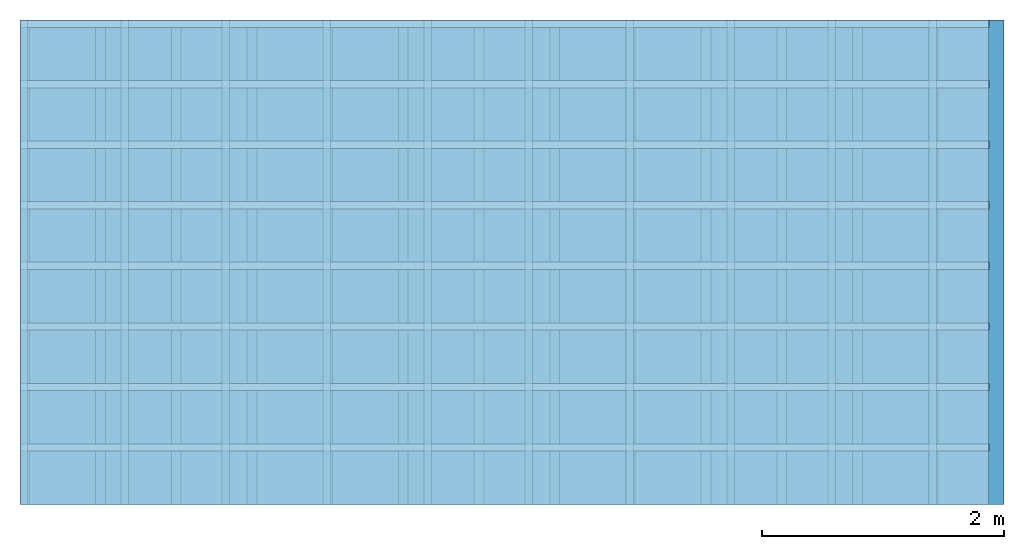
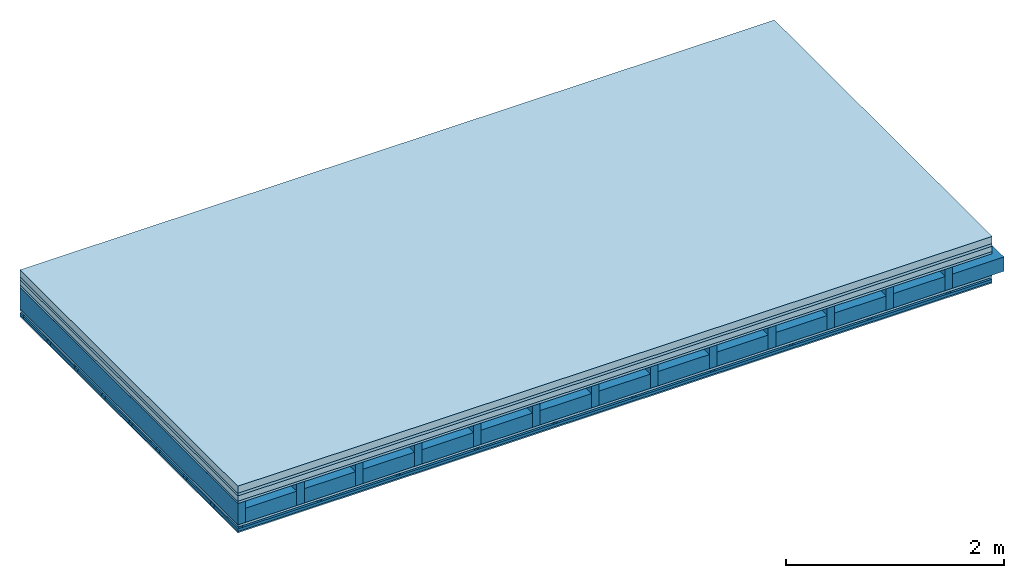
# One storey: 6 plates, 5 members, 1 element without a shape of its own.
"""IFC4 building model written with IfcOpenShell, lengths in metres."""

from ifc_helpers import new_model, si_unit, derived_unit, direction, frame, frame_2d, origin, origin_with_axes, place, context, project, spatial, polyline, rectangle, outline, extrude, material, layer, layer_set, type_object, element, aggregate, save


model = new_model("IFC4")

# Units and contexts
plan_context = context("Plan", 3, precision=1e-05, world=origin(), true_north=direction((0.0, 1.0)))
model_context = context("Model", 3, precision=1e-05, world=origin(), true_north=direction((0.0, 1.0)))
ifc_project = project(units=[si_unit("LENGTHUNIT", "METRE"), derived_unit("SOUNDPRESSUREUNIT", [(si_unit("PRESSUREUNIT", "PASCAL", prefix="MICRO"), 0)]), si_unit("ENERGYUNIT", "JOULE", prefix="MEGA"), si_unit("MASSUNIT", "GRAM", prefix="KILO"), derived_unit("THERMALTRANSMITTANCEUNIT", [(si_unit("POWERUNIT", "WATT"), 1), (si_unit("AREAUNIT", "SQUARE_METRE"), -1), (si_unit("THERMODYNAMICTEMPERATUREUNIT", "KELVIN"), -1)]), derived_unit("AREADENSITYUNIT", [(si_unit("MASSUNIT", "GRAM", prefix="KILO"), 1), (si_unit("AREAUNIT", "SQUARE_METRE"), -1)]), derived_unit("USERDEFINED", [(si_unit("ENERGYUNIT", "JOULE", prefix="MEGA"), 1), (si_unit("AREAUNIT", "SQUARE_METRE"), -1)])], contexts=[plan_context, model_context])

# Site, building, storey
site = spatial("IfcSite", under=ifc_project)
building_placement = place(None, origin())
building = spatial("IfcBuilding", under=site, at=building_placement)
storey_placement = place(building_placement, origin())
storey = spatial("IfcBuildingStorey", under=building, at=storey_placement)

# Slab, members, plates
ifc_material_1 = material(Name="Cement screed", Category="04.006")
ifc_layer_1 = layer(ifc_material_1, 0.08, Name="On-material")
ifc_material_2 = material()
ifc_layer_2 = layer(ifc_material_2, 0.03, Name="Impact sound insulation")
ifc_material_3 = material(Name="Cement panels, glued on sub-floor", Category="02.007")
ifc_layer_3 = layer(ifc_material_3, 0.06, Name="on Supporting structure")
ifc_material_4 = material(Category="07.001")
ifc_layer_4 = layer(ifc_material_4, 0.025, Name="Sub-floor")
ifc_material_5 = material(Name="Rigid, of the art")
ifc_layer_5 = layer(ifc_material_5, 0.0, Name="Bond")
ifc_layer_6 = layer(None, 0.24, Name="Supporting structure")
ifc_layer_7 = layer(ifc_material_5, 0.0, Name="Bond")
ifc_layer_8 = layer(ifc_material_4, 0.025, Name="Lower layer 1")
ifc_layer_9 = layer(None, 0.02, Name="Coupling")
ifc_layer_10 = layer(None, 0.03, Name="Battens / profiles")
ifc_material_6 = material(Category="03.007")
ifc_layer_11 = layer(ifc_material_6, 0.015, Name="Ceiling covering 1st layer")
ifc_material_7 = material(Name="Glued joints")
ifc_layer_12 = layer(ifc_material_7, 0.0, Name="Surface / treatment")
ifc_layer_set = layer_set([ifc_layer_1, ifc_layer_2, ifc_layer_3, ifc_layer_4, ifc_layer_5, ifc_layer_6, ifc_layer_7, ifc_layer_8, ifc_layer_9, ifc_layer_10, ifc_layer_11, ifc_layer_12])
slab_type = type_object("IfcSlabType", Name="A0483", PredefinedType="NOTDEFINED", material=ifc_layer_set)
slab_placement = place(None, frame((0.0, 0.0, 0.0), z_axis=(0.0, 0.0, -1.0), x_axis=(1.0, 0.0, 0.0)))
slab = element("IfcSlab", 1, at=slab_placement, inside=storey, type_object=slab_type, material=ifc_layer_set, Name="Slab #1")
ifc_material_8 = material()
member_1_placement = place(slab_placement, origin())
member_1 = element("IfcMember", 2, at=member_1_placement, material=ifc_material_8, Name="Supporting structure", context=plan_context, shape_type="SweptSolid", body=[
    extrude(rectangle(XDim=0.08, YDim=0.24, at=frame_2d((0.04, 0.12), x_axis=(1.0, 0.0))), frame((0.0, 4.0, 0.195), z_axis=(0.0, -1.0, 0.0), x_axis=(1.0, 0.0, 0.0)), (0.0, 0.0, 1.0), 4.0),
    extrude(rectangle(XDim=0.08, YDim=0.24, at=frame_2d((0.04, 0.12), x_axis=(1.0, 0.0))), frame((0.625, 4.0, 0.195), z_axis=(0.0, -1.0, 0.0), x_axis=(1.0, 0.0, 0.0)), (0.0, 0.0, 1.0), 4.0),
    extrude(rectangle(XDim=0.08, YDim=0.24, at=frame_2d((0.04, 0.12), x_axis=(1.0, 0.0))), frame((1.25, 4.0, 0.195), z_axis=(0.0, -1.0, 0.0), x_axis=(1.0, 0.0, 0.0)), (0.0, 0.0, 1.0), 4.0),
    extrude(rectangle(XDim=0.08, YDim=0.24, at=frame_2d((0.04, 0.12), x_axis=(1.0, 0.0))), frame((1.875, 4.0, 0.195), z_axis=(0.0, -1.0, 0.0), x_axis=(1.0, 0.0, 0.0)), (0.0, 0.0, 1.0), 4.0),
    extrude(rectangle(XDim=0.08, YDim=0.24, at=frame_2d((0.04, 0.12), x_axis=(1.0, 0.0))), frame((2.5, 4.0, 0.195), z_axis=(0.0, -1.0, 0.0), x_axis=(1.0, 0.0, 0.0)), (0.0, 0.0, 1.0), 4.0),
    extrude(rectangle(XDim=0.08, YDim=0.24, at=frame_2d((0.04, 0.12), x_axis=(1.0, 0.0))), frame((3.125, 4.0, 0.195), z_axis=(0.0, -1.0, 0.0), x_axis=(1.0, 0.0, 0.0)), (0.0, 0.0, 1.0), 4.0),
    extrude(rectangle(XDim=0.08, YDim=0.24, at=frame_2d((0.04, 0.12), x_axis=(1.0, 0.0))), frame((3.75, 4.0, 0.195), z_axis=(0.0, -1.0, 0.0), x_axis=(1.0, 0.0, 0.0)), (0.0, 0.0, 1.0), 4.0),
    extrude(rectangle(XDim=0.08, YDim=0.24, at=frame_2d((0.04, 0.12), x_axis=(1.0, 0.0))), frame((4.375, 4.0, 0.195), z_axis=(0.0, -1.0, 0.0), x_axis=(1.0, 0.0, 0.0)), (0.0, 0.0, 1.0), 4.0),
    extrude(rectangle(XDim=0.08, YDim=0.24, at=frame_2d((0.04, 0.12), x_axis=(1.0, 0.0))), frame((5.0, 4.0, 0.195), z_axis=(0.0, -1.0, 0.0), x_axis=(1.0, 0.0, 0.0)), (0.0, 0.0, 1.0), 4.0),
    extrude(rectangle(XDim=0.08, YDim=0.24, at=frame_2d((0.04, 0.12), x_axis=(1.0, 0.0))), frame((5.625, 4.0, 0.195), z_axis=(0.0, -1.0, 0.0), x_axis=(1.0, 0.0, 0.0)), (0.0, 0.0, 1.0), 4.0),
    extrude(rectangle(XDim=0.08, YDim=0.24, at=frame_2d((0.04, 0.12), x_axis=(1.0, 0.0))), frame((6.25, 4.0, 0.195), z_axis=(0.0, -1.0, 0.0), x_axis=(1.0, 0.0, 0.0)), (0.0, 0.0, 1.0), 4.0),
    extrude(rectangle(XDim=0.08, YDim=0.24, at=frame_2d((0.04, 0.12), x_axis=(1.0, 0.0))), frame((6.875, 4.0, 0.195), z_axis=(0.0, -1.0, 0.0), x_axis=(1.0, 0.0, 0.0)), (0.0, 0.0, 1.0), 4.0),
    extrude(rectangle(XDim=0.08, YDim=0.24, at=frame_2d((0.04, 0.12), x_axis=(1.0, 0.0))), frame((7.5, 4.0, 0.195), z_axis=(0.0, -1.0, 0.0), x_axis=(1.0, 0.0, 0.0)), (0.0, 0.0, 1.0), 4.0),
])
ifc_material_9 = material()
member_2_placement = place(slab_placement, origin())
member_2 = element("IfcMember", 3, at=member_2_placement, material=ifc_material_9, Name="Cavity", context=plan_context, shape_type="SweptSolid", body=[
    extrude(rectangle(XDim=0.545, YDim=0.16, at=frame_2d((0.2725, 0.08), x_axis=(1.0, 0.0))), frame((0.08, 4.0, 0.275), z_axis=(0.0, -1.0, 0.0), x_axis=(1.0, 0.0, 0.0)), (0.0, 0.0, 1.0), 4.0),
    extrude(rectangle(XDim=0.545, YDim=0.16, at=frame_2d((0.2725, 0.08), x_axis=(1.0, 0.0))), frame((0.705, 4.0, 0.275), z_axis=(0.0, -1.0, 0.0), x_axis=(1.0, 0.0, 0.0)), (0.0, 0.0, 1.0), 4.0),
    extrude(rectangle(XDim=0.545, YDim=0.16, at=frame_2d((0.2725, 0.08), x_axis=(1.0, 0.0))), frame((1.33, 4.0, 0.275), z_axis=(0.0, -1.0, 0.0), x_axis=(1.0, 0.0, 0.0)), (0.0, 0.0, 1.0), 4.0),
    extrude(rectangle(XDim=0.545, YDim=0.16, at=frame_2d((0.2725, 0.08), x_axis=(1.0, 0.0))), frame((1.955, 4.0, 0.275), z_axis=(0.0, -1.0, 0.0), x_axis=(1.0, 0.0, 0.0)), (0.0, 0.0, 1.0), 4.0),
    extrude(rectangle(XDim=0.545, YDim=0.16, at=frame_2d((0.2725, 0.08), x_axis=(1.0, 0.0))), frame((2.58, 4.0, 0.275), z_axis=(0.0, -1.0, 0.0), x_axis=(1.0, 0.0, 0.0)), (0.0, 0.0, 1.0), 4.0),
    extrude(rectangle(XDim=0.545, YDim=0.16, at=frame_2d((0.2725, 0.08), x_axis=(1.0, 0.0))), frame((3.205, 4.0, 0.275), z_axis=(0.0, -1.0, 0.0), x_axis=(1.0, 0.0, 0.0)), (0.0, 0.0, 1.0), 4.0),
    extrude(rectangle(XDim=0.545, YDim=0.16, at=frame_2d((0.2725, 0.08), x_axis=(1.0, 0.0))), frame((3.83, 4.0, 0.275), z_axis=(0.0, -1.0, 0.0), x_axis=(1.0, 0.0, 0.0)), (0.0, 0.0, 1.0), 4.0),
    extrude(rectangle(XDim=0.545, YDim=0.16, at=frame_2d((0.2725, 0.08), x_axis=(1.0, 0.0))), frame((4.455, 4.0, 0.275), z_axis=(0.0, -1.0, 0.0), x_axis=(1.0, 0.0, 0.0)), (0.0, 0.0, 1.0), 4.0),
    extrude(rectangle(XDim=0.545, YDim=0.16, at=frame_2d((0.2725, 0.08), x_axis=(1.0, 0.0))), frame((5.08, 4.0, 0.275), z_axis=(0.0, -1.0, 0.0), x_axis=(1.0, 0.0, 0.0)), (0.0, 0.0, 1.0), 4.0),
    extrude(rectangle(XDim=0.545, YDim=0.16, at=frame_2d((0.2725, 0.08), x_axis=(1.0, 0.0))), frame((5.705, 4.0, 0.275), z_axis=(0.0, -1.0, 0.0), x_axis=(1.0, 0.0, 0.0)), (0.0, 0.0, 1.0), 4.0),
    extrude(rectangle(XDim=0.545, YDim=0.16, at=frame_2d((0.2725, 0.08), x_axis=(1.0, 0.0))), frame((6.33, 4.0, 0.275), z_axis=(0.0, -1.0, 0.0), x_axis=(1.0, 0.0, 0.0)), (0.0, 0.0, 1.0), 4.0),
    extrude(rectangle(XDim=0.545, YDim=0.16, at=frame_2d((0.2725, 0.08), x_axis=(1.0, 0.0))), frame((6.955, 4.0, 0.275), z_axis=(0.0, -1.0, 0.0), x_axis=(1.0, 0.0, 0.0)), (0.0, 0.0, 1.0), 4.0),
    extrude(rectangle(XDim=0.545, YDim=0.16, at=frame_2d((0.2725, 0.08), x_axis=(1.0, 0.0))), frame((7.58, 4.0, 0.275), z_axis=(0.0, -1.0, 0.0), x_axis=(1.0, 0.0, 0.0)), (0.0, 0.0, 1.0), 4.0),
])
ifc_material_10 = material()
member_3_placement = place(slab_placement, origin())
member_3 = element("IfcMember", 4, at=member_3_placement, material=ifc_material_10, Name="Coupling", context=plan_context, shape_type="SweptSolid", body=[
    extrude(outline(polyline([(0.0, 0.0), (0.06, 0.0), (0.04, 0.02), (0.02, 0.02), (0.0, 0.0)])), frame((0.0, 4.0, 0.46), z_axis=(0.0, -1.0, 0.0), x_axis=(1.0, 0.0, 0.0)), (0.0, 0.0, 1.0), 4.0),
    extrude(outline(polyline([(0.0, 0.0), (0.06, 0.0), (0.04, 0.02), (0.02, 0.02), (0.0, 0.0)])), frame((0.834, 4.0, 0.46), z_axis=(0.0, -1.0, 0.0), x_axis=(1.0, 0.0, 0.0)), (0.0, 0.0, 1.0), 4.0),
    extrude(outline(polyline([(0.0, 0.0), (0.06, 0.0), (0.04, 0.02), (0.02, 0.02), (0.0, 0.0)])), frame((1.668, 4.0, 0.46), z_axis=(0.0, -1.0, 0.0), x_axis=(1.0, 0.0, 0.0)), (0.0, 0.0, 1.0), 4.0),
    extrude(outline(polyline([(0.0, 0.0), (0.06, 0.0), (0.04, 0.02), (0.02, 0.02), (0.0, 0.0)])), frame((2.502, 4.0, 0.46), z_axis=(0.0, -1.0, 0.0), x_axis=(1.0, 0.0, 0.0)), (0.0, 0.0, 1.0), 4.0),
    extrude(outline(polyline([(0.0, 0.0), (0.06, 0.0), (0.04, 0.02), (0.02, 0.02), (0.0, 0.0)])), frame((3.336, 4.0, 0.46), z_axis=(0.0, -1.0, 0.0), x_axis=(1.0, 0.0, 0.0)), (0.0, 0.0, 1.0), 4.0),
    extrude(outline(polyline([(0.0, 0.0), (0.06, 0.0), (0.04, 0.02), (0.02, 0.02), (0.0, 0.0)])), frame((4.17, 4.0, 0.46), z_axis=(0.0, -1.0, 0.0), x_axis=(1.0, 0.0, 0.0)), (0.0, 0.0, 1.0), 4.0),
    extrude(outline(polyline([(0.0, 0.0), (0.06, 0.0), (0.04, 0.02), (0.02, 0.02), (0.0, 0.0)])), frame((5.004, 4.0, 0.46), z_axis=(0.0, -1.0, 0.0), x_axis=(1.0, 0.0, 0.0)), (0.0, 0.0, 1.0), 4.0),
    extrude(outline(polyline([(0.0, 0.0), (0.06, 0.0), (0.04, 0.02), (0.02, 0.02), (0.0, 0.0)])), frame((5.838, 4.0, 0.46), z_axis=(0.0, -1.0, 0.0), x_axis=(1.0, 0.0, 0.0)), (0.0, 0.0, 1.0), 4.0),
    extrude(outline(polyline([(0.0, 0.0), (0.06, 0.0), (0.04, 0.02), (0.02, 0.02), (0.0, 0.0)])), frame((6.672, 4.0, 0.46), z_axis=(0.0, -1.0, 0.0), x_axis=(1.0, 0.0, 0.0)), (0.0, 0.0, 1.0), 4.0),
    extrude(outline(polyline([(0.0, 0.0), (0.06, 0.0), (0.04, 0.02), (0.02, 0.02), (0.0, 0.0)])), frame((7.506, 4.0, 0.46), z_axis=(0.0, -1.0, 0.0), x_axis=(1.0, 0.0, 0.0)), (0.0, 0.0, 1.0), 4.0),
])
ifc_material_11 = material()
member_4_placement = place(slab_placement, origin())
member_4 = element("IfcMember", 5, at=member_4_placement, material=ifc_material_11, Name="Battens / profiles", context=plan_context, shape_type="SweptSolid", body=[
    extrude(rectangle(XDim=0.06, YDim=0.03, at=frame_2d((0.03, 0.015), x_axis=(1.0, 0.0))), frame((0.0, 0.0, 0.48), z_axis=(1.0, 0.0, 0.0), x_axis=(0.0, 1.0, 0.0)), (0.0, 0.0, 1.0), 8.0),
    extrude(rectangle(XDim=0.06, YDim=0.03, at=frame_2d((0.03, 0.015), x_axis=(1.0, 0.0))), frame((0.0, 0.5, 0.48), z_axis=(1.0, 0.0, 0.0), x_axis=(0.0, 1.0, 0.0)), (0.0, 0.0, 1.0), 8.0),
    extrude(rectangle(XDim=0.06, YDim=0.03, at=frame_2d((0.03, 0.015), x_axis=(1.0, 0.0))), frame((0.0, 1.0, 0.48), z_axis=(1.0, 0.0, 0.0), x_axis=(0.0, 1.0, 0.0)), (0.0, 0.0, 1.0), 8.0),
    extrude(rectangle(XDim=0.06, YDim=0.03, at=frame_2d((0.03, 0.015), x_axis=(1.0, 0.0))), frame((0.0, 1.5, 0.48), z_axis=(1.0, 0.0, 0.0), x_axis=(0.0, 1.0, 0.0)), (0.0, 0.0, 1.0), 8.0),
    extrude(rectangle(XDim=0.06, YDim=0.03, at=frame_2d((0.03, 0.015), x_axis=(1.0, 0.0))), frame((0.0, 2.0, 0.48), z_axis=(1.0, 0.0, 0.0), x_axis=(0.0, 1.0, 0.0)), (0.0, 0.0, 1.0), 8.0),
    extrude(rectangle(XDim=0.06, YDim=0.03, at=frame_2d((0.03, 0.015), x_axis=(1.0, 0.0))), frame((0.0, 2.5, 0.48), z_axis=(1.0, 0.0, 0.0), x_axis=(0.0, 1.0, 0.0)), (0.0, 0.0, 1.0), 8.0),
    extrude(rectangle(XDim=0.06, YDim=0.03, at=frame_2d((0.03, 0.015), x_axis=(1.0, 0.0))), frame((0.0, 3.0, 0.48), z_axis=(1.0, 0.0, 0.0), x_axis=(0.0, 1.0, 0.0)), (0.0, 0.0, 1.0), 8.0),
    extrude(rectangle(XDim=0.06, YDim=0.03, at=frame_2d((0.03, 0.015), x_axis=(1.0, 0.0))), frame((0.0, 3.5, 0.48), z_axis=(1.0, 0.0, 0.0), x_axis=(0.0, 1.0, 0.0)), (0.0, 0.0, 1.0), 8.0),
])
member_5_placement = place(slab_placement, origin())
member_5 = element("IfcMember", 6, at=member_5_placement, material=ifc_material_9, Name="Cavity", context=plan_context, shape_type="SweptSolid", body=[
    extrude(rectangle(XDim=0.44, YDim=0.03, at=frame_2d((0.22, 0.015), x_axis=(1.0, 0.0))), frame((0.0, 0.06, 0.48), z_axis=(1.0, 0.0, 0.0), x_axis=(0.0, 1.0, 0.0)), (0.0, 0.0, 1.0), 8.0),
    extrude(rectangle(XDim=0.44, YDim=0.03, at=frame_2d((0.22, 0.015), x_axis=(1.0, 0.0))), frame((0.0, 0.56, 0.48), z_axis=(1.0, 0.0, 0.0), x_axis=(0.0, 1.0, 0.0)), (0.0, 0.0, 1.0), 8.0),
    extrude(rectangle(XDim=0.44, YDim=0.03, at=frame_2d((0.22, 0.015), x_axis=(1.0, 0.0))), frame((0.0, 1.06, 0.48), z_axis=(1.0, 0.0, 0.0), x_axis=(0.0, 1.0, 0.0)), (0.0, 0.0, 1.0), 8.0),
    extrude(rectangle(XDim=0.44, YDim=0.03, at=frame_2d((0.22, 0.015), x_axis=(1.0, 0.0))), frame((0.0, 1.56, 0.48), z_axis=(1.0, 0.0, 0.0), x_axis=(0.0, 1.0, 0.0)), (0.0, 0.0, 1.0), 8.0),
    extrude(rectangle(XDim=0.44, YDim=0.03, at=frame_2d((0.22, 0.015), x_axis=(1.0, 0.0))), frame((0.0, 2.06, 0.48), z_axis=(1.0, 0.0, 0.0), x_axis=(0.0, 1.0, 0.0)), (0.0, 0.0, 1.0), 8.0),
    extrude(rectangle(XDim=0.44, YDim=0.03, at=frame_2d((0.22, 0.015), x_axis=(1.0, 0.0))), frame((0.0, 2.56, 0.48), z_axis=(1.0, 0.0, 0.0), x_axis=(0.0, 1.0, 0.0)), (0.0, 0.0, 1.0), 8.0),
    extrude(rectangle(XDim=0.44, YDim=0.03, at=frame_2d((0.22, 0.015), x_axis=(1.0, 0.0))), frame((0.0, 3.06, 0.48), z_axis=(1.0, 0.0, 0.0), x_axis=(0.0, 1.0, 0.0)), (0.0, 0.0, 1.0), 8.0),
    extrude(rectangle(XDim=0.44, YDim=0.03, at=frame_2d((0.22, 0.015), x_axis=(1.0, 0.0))), frame((0.0, 3.56, 0.48), z_axis=(1.0, 0.0, 0.0), x_axis=(0.0, 1.0, 0.0)), (0.0, 0.0, 1.0), 8.0),
])
plate_1_placement = place(slab_placement, origin())
plate_1 = element("IfcPlate", 7, at=plate_1_placement, material=ifc_material_1, Name="On-material", context=plan_context, shape_type="SweptSolid", body=[
    extrude(rectangle(XDim=8.0, YDim=4.0, at=frame_2d((4.0, 2.0), x_axis=(1.0, 0.0))), origin_with_axes(), (0.0, 0.0, 1.0), 0.08),
])
plate_2_placement = place(slab_placement, origin())
plate_2 = element("IfcPlate", 8, at=plate_2_placement, material=ifc_material_2, Name="Impact sound insulation", context=plan_context, shape_type="SweptSolid", body=[
    extrude(rectangle(XDim=8.0, YDim=4.0, at=frame_2d((4.0, 2.0), x_axis=(1.0, 0.0))), frame((0.0, 0.0, 0.08), z_axis=(0.0, 0.0, 1.0), x_axis=(1.0, 0.0, 0.0)), (0.0, 0.0, 1.0), 0.03),
])
plate_3_placement = place(slab_placement, origin())
plate_3 = element("IfcPlate", 9, at=plate_3_placement, material=ifc_material_3, Name="on Supporting structure", context=plan_context, shape_type="SweptSolid", body=[
    extrude(rectangle(XDim=8.0, YDim=4.0, at=frame_2d((4.0, 2.0), x_axis=(1.0, 0.0))), frame((0.0, 0.0, 0.11), z_axis=(0.0, 0.0, 1.0), x_axis=(1.0, 0.0, 0.0)), (0.0, 0.0, 1.0), 0.06),
])
plate_4_placement = place(slab_placement, origin())
plate_4 = element("IfcPlate", 10, at=plate_4_placement, material=ifc_material_4, Name="Sub-floor", context=plan_context, shape_type="SweptSolid", body=[
    extrude(rectangle(XDim=8.0, YDim=4.0, at=frame_2d((4.0, 2.0), x_axis=(1.0, 0.0))), frame((0.0, 0.0, 0.17), z_axis=(0.0, 0.0, 1.0), x_axis=(1.0, 0.0, 0.0)), (0.0, 0.0, 1.0), 0.025),
])
plate_5_placement = place(slab_placement, origin())
plate_5 = element("IfcPlate", 11, at=plate_5_placement, material=ifc_material_4, Name="Lower layer 1", context=plan_context, shape_type="SweptSolid", body=[
    extrude(rectangle(XDim=8.0, YDim=4.0, at=frame_2d((4.0, 2.0), x_axis=(1.0, 0.0))), frame((0.0, 0.0, 0.435), z_axis=(0.0, 0.0, 1.0), x_axis=(1.0, 0.0, 0.0)), (0.0, 0.0, 1.0), 0.025),
])
plate_6_placement = place(slab_placement, origin())
plate_6 = element("IfcPlate", 12, at=plate_6_placement, material=ifc_material_6, Name="Ceiling covering 1st layer", context=plan_context, shape_type="SweptSolid", body=[
    extrude(rectangle(XDim=8.0, YDim=4.0, at=frame_2d((4.0, 2.0), x_axis=(1.0, 0.0))), frame((0.0, 0.0, 0.51), z_axis=(0.0, 0.0, 1.0), x_axis=(1.0, 0.0, 0.0)), (0.0, 0.0, 1.0), 0.015),
])
aggregate(slab, [plate_1, plate_2, plate_3, plate_4, member_1, member_2, plate_5, member_3, member_4, member_5, plate_6])

save(model, "model.ifc")
